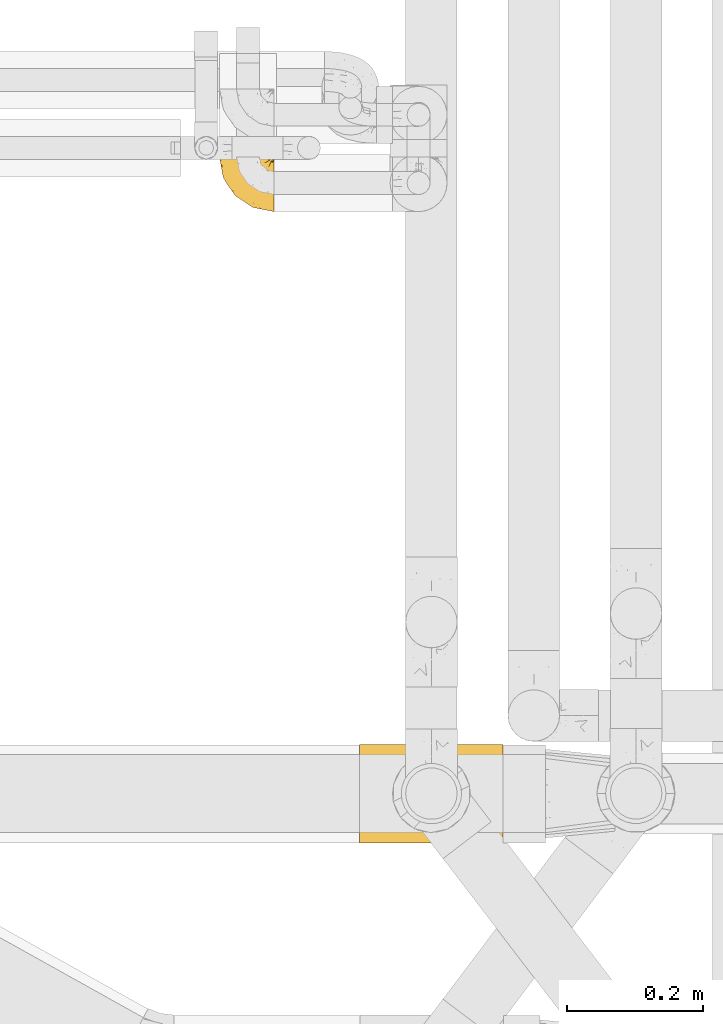
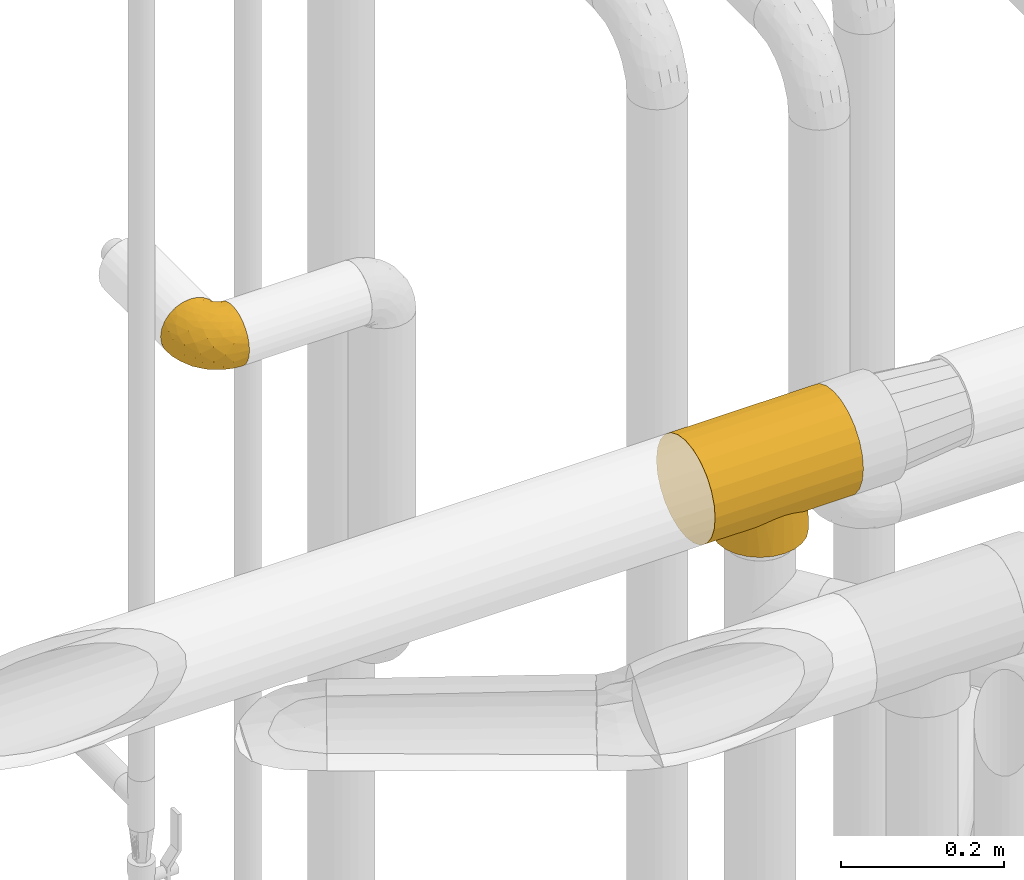
# One storey, part 353 of 827: 2 coverings.
"""IFC2X3 building model written with IfcOpenShell, lengths in millimetres."""

from ifc_helpers import new_model, entity, si_unit, converted_unit, derived_unit, direction, frame, origin, place, context, subcontext, project, spatial, faceted_brep, element, save


model = new_model("IFC2X3")

# Units and contexts
model_context = context("Model", 3, precision=0.01, world=origin(), true_north=direction((6.12303176911189e-17, 1.0)))
body_context = subcontext(model_context, "Body", "Model", "MODEL_VIEW")
ifc_project = project(units=[si_unit("LENGTHUNIT", "METRE", prefix="MILLI"), si_unit("AREAUNIT", "SQUARE_METRE"), si_unit("VOLUMEUNIT", "CUBIC_METRE"), converted_unit("PLANEANGLEUNIT", "DEGREE", entity("IfcRatioMeasure", 0.0174532925199433), si_unit("PLANEANGLEUNIT", "RADIAN"), dimensions=[0, 0, 0, 0, 0, 0, 0]), si_unit("MASSUNIT", "GRAM", prefix="KILO"), derived_unit("MASSDENSITYUNIT", [(si_unit("MASSUNIT", "GRAM", prefix="KILO"), 1), (si_unit("LENGTHUNIT", "METRE"), -3)]), derived_unit("MOMENTOFINERTIAUNIT", [(si_unit("LENGTHUNIT", "METRE"), 4)]), si_unit("TIMEUNIT", "SECOND"), si_unit("FREQUENCYUNIT", "HERTZ"), si_unit("THERMODYNAMICTEMPERATUREUNIT", "DEGREE_CELSIUS"), derived_unit("THERMALTRANSMITTANCEUNIT", [(si_unit("MASSUNIT", "GRAM", prefix="KILO"), 1), (si_unit("THERMODYNAMICTEMPERATUREUNIT", "KELVIN"), -1), (si_unit("TIMEUNIT", "SECOND"), -3)]), derived_unit("VOLUMETRICFLOWRATEUNIT", [(si_unit("LENGTHUNIT", "METRE"), 3), (si_unit("TIMEUNIT", "SECOND"), -1)]), derived_unit("MASSFLOWRATEUNIT", [(si_unit("MASSUNIT", "GRAM", prefix="KILO"), 1), (si_unit("TIMEUNIT", "SECOND"), -1)]), derived_unit("ROTATIONALFREQUENCYUNIT", [(si_unit("TIMEUNIT", "SECOND"), -1)]), si_unit("ELECTRICCURRENTUNIT", "AMPERE"), si_unit("ELECTRICVOLTAGEUNIT", "VOLT"), si_unit("POWERUNIT", "WATT"), si_unit("FORCEUNIT", "NEWTON", prefix="KILO"), si_unit("ILLUMINANCEUNIT", "LUX"), si_unit("LUMINOUSFLUXUNIT", "LUMEN"), si_unit("LUMINOUSINTENSITYUNIT", "CANDELA"), derived_unit("USERDEFINED", [(si_unit("MASSUNIT", "GRAM", prefix="KILO"), -1), (si_unit("LENGTHUNIT", "METRE"), -2), (si_unit("TIMEUNIT", "SECOND"), 3), (si_unit("LUMINOUSFLUXUNIT", "LUMEN"), 1)]), derived_unit("LINEARVELOCITYUNIT", [(si_unit("LENGTHUNIT", "METRE"), 1), (si_unit("TIMEUNIT", "SECOND"), -1)]), si_unit("PRESSUREUNIT", "PASCAL"), derived_unit("USERDEFINED", [(si_unit("LENGTHUNIT", "METRE"), -2), (si_unit("MASSUNIT", "GRAM", prefix="KILO"), 1), (si_unit("TIMEUNIT", "SECOND"), -2)]), derived_unit("LINEARFORCEUNIT", [(si_unit("MASSUNIT", "GRAM", prefix="KILO"), 1), (si_unit("LENGTHUNIT", "METRE"), 1), (si_unit("TIMEUNIT", "SECOND"), -2), (si_unit("LENGTHUNIT", "METRE"), -1)]), derived_unit("PLANARFORCEUNIT", [(si_unit("MASSUNIT", "GRAM", prefix="KILO"), 1), (si_unit("LENGTHUNIT", "METRE"), 1), (si_unit("TIMEUNIT", "SECOND"), -2), (si_unit("LENGTHUNIT", "METRE"), -2)])], contexts=[model_context])

# Site, building, storey
site_placement = place(None, origin())
site = spatial("IfcSite", under=ifc_project, at=site_placement, CompositionType="ELEMENT")
building_placement = place(site_placement, origin())
building = spatial("IfcBuilding", under=site, at=building_placement, CompositionType="ELEMENT")
storey_placement = place(building_placement, frame((0.0, 0.0, 28200.0)))
storey = spatial("IfcBuildingStorey", under=building, at=storey_placement, Name="08", CompositionType="ELEMENT", Elevation=28200.0)

# Coverings
covering_1_placement = place(storey_placement, frame((43282.77, 15137.81, 2190.84)))
element("IfcCovering", 1, at=covering_1_placement, inside=storey, Name=":ADSK_", ObjectType=":ADSK_", PredefinedType="INSULATION", context=body_context, shape_type="Brep", body=[
    faceted_brep([(81.45, 25.28, 81.15), (81.45, 17.35, 76.16), (81.45, 10.72, 69.53), (81.45, 5.74, 61.6), (81.45, 2.64, 52.75), (81.45, 1.6, 43.45), (81.45, 2.65, 34.13), (81.45, 5.74, 25.28), (81.45, 10.73, 17.35), (81.45, 17.36, 10.72), (81.45, 25.29, 5.74), (81.45, 34.14, 2.64), (81.45, 43.45, 1.6), (81.45, 52.82, 2.66), (81.45, 61.71, 5.79), (81.45, 69.67, 10.83), (81.45, 76.31, 17.53), (81.45, 81.27, 25.53), (81.45, 81.27, 26.45), (81.45, 81.27, 27.37), (81.45, 81.27, 28.17), (81.45, 81.27, 29.49), (81.45, 81.27, 30.81), (81.45, 81.27, 32.13), (81.45, 81.27, 33.45), (81.45, 81.27, 34.78), (81.45, 81.27, 36.1), (81.45, 81.27, 37.42), (81.45, 81.27, 38.74), (81.45, 81.27, 40.06), (81.45, 81.27, 41.38), (81.45, 81.27, 42.7), (81.45, 81.27, 44.02), (81.45, 81.27, 45.34), (81.45, 81.27, 46.66), (81.45, 81.27, 47.58), (81.45, 81.27, 48.5), (81.45, 81.27, 49.41), (81.45, 81.27, 50.33), (81.45, 81.27, 51.25), (81.45, 81.27, 52.17), (81.45, 81.27, 53.09), (81.45, 81.27, 54.01), (81.45, 81.27, 54.93), (81.45, 81.27, 55.85), (81.45, 81.27, 56.76), (81.45, 81.27, 57.68), (81.45, 81.27, 58.6), (81.45, 81.27, 59.52), (81.45, 81.27, 60.44), (81.45, 81.27, 61.36), (81.45, 76.3, 69.37), (81.45, 69.66, 76.07), (81.45, 61.69, 81.11), (81.45, 52.8, 84.24), (81.45, 43.45, 85.3), (81.45, 34.13, 84.24), (76.3, 81.45, 17.52), (69.67, 81.45, 10.83), (61.7, 81.45, 5.79), (52.81, 81.45, 2.66), (43.45, 81.45, 1.6), (32.61, 81.45, 3.02), (22.52, 81.45, 7.2), (13.85, 81.45, 13.85), (7.2, 81.45, 22.52), (3.02, 81.45, 32.61), (1.6, 81.45, 43.45), (3.02, 81.45, 54.28), (7.2, 81.45, 64.37), (13.85, 81.45, 73.04), (22.52, 81.45, 79.69), (32.61, 81.45, 83.87), (43.45, 81.45, 85.3), (52.81, 81.45, 84.23), (61.7, 81.45, 81.1), (69.67, 81.45, 76.06), (76.3, 81.45, 69.37), (81.27, 81.45, 61.36), (81.27, 81.45, 60.44), (81.27, 81.45, 59.12), (81.27, 81.45, 58.0), (81.27, 81.45, 56.88), (81.27, 81.45, 55.76), (81.27, 81.45, 54.64), (81.27, 81.45, 53.52), (81.27, 81.45, 52.4), (81.27, 81.45, 51.28), (81.27, 81.45, 50.16), (81.27, 81.45, 49.04), (81.27, 81.45, 47.92), (81.27, 81.45, 46.8), (81.27, 81.45, 45.68), (81.27, 81.45, 44.56), (81.27, 81.45, 43.45), (81.27, 81.45, 42.12), (81.27, 81.45, 40.8), (81.27, 81.45, 39.48), (81.27, 81.45, 38.16), (81.27, 81.45, 36.84), (81.27, 81.45, 35.52), (81.27, 81.45, 34.2), (81.27, 81.45, 32.88), (81.27, 81.45, 31.96), (81.27, 81.45, 31.05), (81.27, 81.45, 30.13), (81.27, 81.45, 29.21), (81.27, 81.45, 28.29), (81.27, 81.45, 27.37), (81.27, 81.45, 26.45), (81.27, 81.45, 25.53), (81.31, 81.33, 54.08), (81.33, 81.32, 55.16), (81.31, 81.33, 36.18), (81.32, 81.32, 35.13), (81.31, 81.33, 44.01), (81.32, 81.32, 45.08), (81.32, 81.32, 61.36), (81.32, 81.32, 59.98), (81.32, 81.32, 46.18), (81.32, 81.32, 26.74), (81.32, 81.32, 47.36), (81.32, 81.32, 29.67), (81.3, 81.34, 28.72), (81.32, 81.32, 39.77), (81.33, 81.31, 52.96), (81.31, 81.33, 51.84), (81.33, 81.31, 40.8), (81.32, 81.32, 41.87), (81.32, 81.33, 42.94), (81.32, 81.32, 27.77), (81.31, 81.33, 48.4), (81.32, 81.32, 37.21), (81.31, 81.33, 33.54), (81.32, 81.32, 32.49), (81.32, 81.32, 30.69), (81.32, 81.32, 50.69), (81.33, 81.31, 49.6), (81.32, 81.32, 56.32), (81.31, 81.33, 57.44), (81.33, 81.31, 58.88), (81.32, 81.32, 25.53), (81.36, 81.3, 61.36), (81.4, 81.29, 61.36), (81.4, 81.29, 25.53), (81.36, 81.3, 25.53), (81.29, 81.4, 61.36), (81.3, 81.36, 61.36), (81.3, 81.36, 25.53), (81.29, 81.4, 25.53), (81.35, 81.3, 31.59), (81.31, 81.33, 38.71), (58.5, 74.06, 3.97), (71.95, 45.99, 1.6), (74.57, 58.35, 3.97), (73.93, 67.76, 8.09), (78.18, 66.18, 8.09), (78.04, 76.46, 16.43), (76.23, 77.33, 15.73), (45.99, 71.95, 1.6), (74.01, 72.25, 10.79), (73.57, 78.91, 13.99), (66.66, 76.42, 8.08), (79.09, 73.52, 14.0), (73.14, 76.9, 12.83), (60.34, 65.25, 3.18), (48.54, 62.45, 1.6), (45.36, 74.31, 1.6), (67.22, 59.38, 3.28), (62.45, 48.54, 1.6), (68.67, 67.72, 6.28), (55.49, 55.49, 1.6), (77.84, 79.73, 19.06), (68.16, 73.23, 8.08), (74.31, 45.36, 1.6), (38.78, 15.81, 32.11), (62.1, 6.4, 29.62), (50.89, 7.67, 43.45), (36.91, 68.46, 2.45), (40.37, 59.33, 2.5), (27.86, 48.7, 9.73), (15.77, 53.94, 17.97), (20.13, 65.02, 10.24), (31.54, 60.77, 4.78), (28.25, 72.07, 4.78), (57.26, 26.25, 8.01), (69.99, 22.29, 8.01), (64.58, 16.0, 13.85), (50.64, 46.93, 2.42), (51.97, 14.19, 21.17), (5.72, 58.46, 35.73), (7.42, 61.51, 27.43), (66.14, 4.64, 43.45), (11.35, 68.93, 17.97), (21.64, 29.62, 35.71), (28.57, 24.85, 29.47), (55.38, 38.55, 3.41), (68.51, 31.27, 3.94), (67.48, 9.35, 21.17), (40.78, 37.15, 7.92), (41.53, 47.07, 4.25), (46.11, 26.49, 11.75), (40.32, 23.01, 18.31), (38.36, 19.4, 24.94), (11.84, 48.06, 28.78), (12.56, 42.46, 35.82), (7.67, 50.89, 43.45), (19.39, 35.78, 28.38), (24.98, 24.98, 43.45), (37.94, 16.33, 43.45), (4.64, 66.14, 43.45), (28.09, 30.96, 21.21), (23.73, 41.83, 16.48), (34.03, 33.28, 13.85), (16.33, 37.94, 43.45), (29.29, 67.39, 82.11), (5.77, 58.47, 51.41), (21.44, 32.5, 57.45), (38.8, 15.79, 54.78), (64.58, 15.99, 73.03), (67.49, 9.34, 65.7), (22.9, 56.91, 76.65), (12.54, 63.5, 68.92), (20.04, 44.08, 68.01), (57.26, 26.24, 78.88), (69.99, 22.27, 78.88), (68.51, 31.26, 82.94), (34.54, 23.95, 64.44), (38.81, 63.79, 84.49), (48.54, 62.45, 85.3), (45.99, 71.95, 85.3), (74.31, 45.36, 85.3), (5.36, 67.83, 57.84), (18.96, 70.28, 76.65), (12.79, 42.11, 51.19), (62.11, 6.39, 57.26), (33.14, 43.54, 78.14), (33.44, 58.03, 82.35), (51.98, 14.18, 65.7), (43.42, 56.34, 84.61), (48.62, 48.09, 84.36), (62.45, 48.54, 85.3), (55.49, 55.49, 85.3), (49.68, 21.78, 73.03), (55.37, 38.54, 83.48), (71.95, 45.99, 85.3), (36.37, 72.79, 84.54), (34.04, 33.26, 73.03), (44.1, 35.53, 79.54), (9.99, 53.66, 59.46), (26.41, 43.03, 73.5), (39.19, 49.68, 82.57), (58.5, 74.06, 82.92), (67.22, 59.37, 83.62), (74.57, 58.34, 82.92), (73.92, 67.75, 78.81), (73.57, 78.91, 72.9), (73.14, 76.9, 74.06), (66.19, 78.08, 78.81), (68.16, 73.23, 78.81), (77.84, 79.73, 67.83), (76.23, 77.34, 71.15), (79.08, 73.51, 72.91), (78.04, 76.45, 70.47), (77.18, 66.41, 78.81), (68.66, 67.7, 80.62), (74.0, 72.24, 76.11), (60.34, 65.25, 83.71)], [[[0, 1, 2, 3, 4, 5, 6, 7, 8, 9, 10, 11, 12, 13, 14, 15, 16, 17, 18, 19, 20, 21, 22, 23, 24, 25, 26, 27, 28, 29, 30, 31, 32, 33, 34, 35, 36, 37, 38, 39, 40, 41, 42, 43, 44, 45, 46, 47, 48, 49, 50, 51, 52, 53, 54, 55, 56]], [[57, 58, 59, 60, 61, 62, 63, 64, 65, 66, 67, 68, 69, 70, 71, 72, 73, 74, 75, 76, 77, 78, 79, 80, 81, 82, 83, 84, 85, 86, 87, 88, 89, 90, 91, 92, 93, 94, 95, 96, 97, 98, 99, 100, 101, 102, 103, 104, 105, 106, 107, 108, 109, 110]], [[111, 84, 112]], [[113, 26, 114]], [[114, 101, 100]], [[115, 93, 116]], [[79, 117, 118]], [[33, 116, 119]], [[117, 49, 118]], [[19, 18, 120]], [[119, 121, 34]], [[122, 21, 123]], [[97, 96, 124]], [[86, 125, 126]], [[116, 92, 119]], [[127, 96, 128]], [[32, 129, 115]], [[19, 120, 130]], [[121, 90, 131]], [[94, 115, 129]], [[115, 116, 32]], [[118, 49, 48]], [[113, 99, 132]], [[133, 114, 25]], [[24, 134, 133]], [[135, 22, 122]], [[136, 137, 88]], [[84, 83, 112]], [[138, 82, 139]], [[130, 20, 19]], [[118, 48, 140]], [[81, 140, 139]], [[123, 21, 20]], [[141, 120, 18]], [[139, 82, 81]], [[130, 107, 123]], [[49, 117, 142, 143, 50]], [[18, 17, 144, 145, 141]], [[79, 78, 146, 147, 117]], [[109, 141, 148, 149, 110]], [[102, 133, 134]], [[105, 135, 122]], [[118, 80, 79]], [[80, 118, 140]], [[120, 109, 108]], [[47, 46, 140, 48]], [[81, 80, 140]], [[44, 112, 138]], [[93, 115, 94]], [[46, 139, 140]], [[46, 45, 139]], [[139, 45, 138]], [[138, 112, 83]], [[85, 84, 111]], [[112, 43, 111]], [[83, 82, 138]], [[106, 122, 123]], [[105, 122, 106]], [[21, 122, 22]], [[124, 29, 28]], [[33, 32, 116]], [[128, 129, 31]], [[32, 31, 129]], [[34, 33, 119]], [[116, 93, 92]], [[129, 95, 94]], [[95, 129, 128]], [[41, 40, 125, 42]], [[119, 91, 121]], [[36, 35, 131, 37]], [[137, 131, 89]], [[121, 131, 35]], [[90, 121, 91]], [[119, 92, 91]], [[136, 126, 39]], [[125, 86, 85]], [[42, 125, 111]], [[85, 111, 125]], [[150, 23, 22]], [[130, 108, 107]], [[130, 123, 20]], [[107, 106, 123]], [[137, 37, 131]], [[136, 38, 137]], [[89, 88, 137]], [[131, 90, 89]], [[124, 151, 97]], [[40, 39, 126]], [[87, 126, 136]], [[86, 126, 87]], [[136, 88, 87]], [[40, 126, 125]], [[39, 38, 136]], [[95, 128, 96]], [[30, 128, 31]], [[29, 124, 127]], [[127, 128, 30]], [[151, 124, 28]], [[127, 30, 29]], [[127, 124, 96]], [[151, 98, 97]], [[45, 44, 138]], [[26, 113, 132]], [[113, 100, 99]], [[132, 151, 27]], [[27, 26, 132]], [[26, 25, 114]], [[100, 113, 114]], [[101, 133, 102]], [[133, 101, 114]], [[28, 27, 151]], [[132, 99, 98]], [[23, 134, 24]], [[25, 24, 133]], [[134, 23, 150]], [[135, 104, 150]], [[150, 104, 103]], [[103, 102, 134]], [[130, 120, 108]], [[109, 120, 141]], [[42, 111, 43]], [[112, 44, 43]], [[104, 135, 105]], [[134, 150, 103]], [[135, 150, 22]], [[35, 34, 121]], [[137, 38, 37]], [[98, 151, 132]], [[59, 152, 60]], [[13, 153, 154]], [[155, 156, 154]], [[157, 158, 141]], [[159, 60, 152]], [[160, 157, 155]], [[161, 162, 58]], [[58, 162, 59]], [[144, 16, 163]], [[58, 57, 161]], [[162, 161, 164]], [[157, 163, 155]], [[163, 16, 15]], [[57, 149, 161]], [[152, 165, 166]], [[157, 144, 163]], [[60, 159, 167, 61]], [[156, 14, 154]], [[163, 156, 155]], [[155, 154, 168]], [[168, 154, 169]], [[155, 170, 160]], [[57, 110, 149]], [[144, 17, 16]], [[156, 15, 14]], [[171, 165, 168]], [[158, 164, 172]], [[14, 13, 154]], [[157, 141, 145, 144]], [[173, 164, 158]], [[173, 160, 170]], [[171, 166, 165]], [[168, 165, 170]], [[168, 169, 171]], [[152, 173, 165]], [[170, 155, 168]], [[165, 173, 170]], [[160, 173, 158]], [[172, 149, 148]], [[148, 141, 158]], [[158, 157, 160]], [[152, 166, 159]], [[173, 152, 162]], [[59, 162, 152]], [[13, 12, 174, 153]], [[153, 169, 154]], [[15, 156, 163]], [[162, 164, 173]], [[172, 164, 161]], [[149, 172, 161]], [[158, 172, 148]], [[175, 176, 177]], [[178, 166, 179]], [[180, 181, 182]], [[183, 184, 178]], [[185, 186, 187]], [[171, 188, 179]], [[174, 12, 11]], [[189, 176, 175]], [[190, 66, 191]], [[176, 6, 192]], [[193, 65, 64]], [[63, 184, 182]], [[63, 182, 64]], [[65, 193, 191]], [[184, 63, 62]], [[175, 194, 195]], [[196, 169, 197]], [[174, 11, 197]], [[8, 7, 198]], [[187, 9, 8]], [[197, 169, 153, 174]], [[197, 11, 10]], [[186, 197, 10]], [[199, 180, 200]], [[197, 185, 196]], [[201, 189, 202]], [[201, 187, 189]], [[195, 203, 175]], [[191, 204, 190]], [[176, 7, 6]], [[177, 176, 192]], [[189, 198, 176]], [[65, 191, 66]], [[198, 187, 8]], [[205, 206, 190]], [[9, 186, 10]], [[181, 207, 204]], [[208, 175, 177, 209]], [[66, 190, 210]], [[211, 212, 213]], [[190, 204, 205]], [[180, 182, 183]], [[193, 182, 181]], [[62, 61, 167]], [[196, 185, 199]], [[196, 200, 188]], [[6, 5, 192]], [[176, 198, 7]], [[187, 198, 189]], [[187, 186, 9]], [[197, 186, 185]], [[200, 180, 183]], [[180, 213, 212]], [[179, 183, 178]], [[185, 201, 199]], [[210, 190, 206]], [[210, 67, 66]], [[205, 204, 207]], [[194, 205, 207]], [[194, 214, 205]], [[195, 194, 207]], [[208, 194, 175]], [[207, 211, 195]], [[202, 203, 211]], [[212, 207, 181]], [[202, 211, 213]], [[201, 202, 213]], [[189, 175, 203]], [[199, 201, 213]], [[187, 201, 185]], [[180, 199, 213]], [[196, 199, 200]], [[211, 203, 195]], [[189, 203, 202]], [[207, 212, 211]], [[180, 212, 181]], [[214, 194, 208]], [[214, 206, 205]], [[196, 188, 169]], [[181, 204, 191]], [[182, 193, 64]], [[191, 193, 181]], [[178, 62, 167]], [[182, 184, 183]], [[62, 178, 184]], [[178, 167, 159, 166]], [[171, 179, 166]], [[200, 183, 179]], [[179, 188, 200]], [[169, 188, 171]], [[71, 215, 72]], [[206, 216, 210]], [[217, 208, 218]], [[216, 68, 210]], [[219, 220, 2]], [[221, 222, 223]], [[224, 225, 226]], [[227, 223, 217]], [[228, 229, 230]], [[56, 231, 226]], [[232, 222, 69]], [[56, 55, 231]], [[70, 233, 71]], [[71, 233, 215]], [[0, 56, 226]], [[208, 217, 234]], [[218, 177, 235]], [[221, 236, 237]], [[238, 220, 219]], [[1, 219, 2]], [[68, 216, 232]], [[235, 3, 220]], [[235, 192, 4]], [[1, 0, 225]], [[228, 239, 229]], [[240, 241, 242]], [[243, 238, 219]], [[224, 226, 244]], [[226, 241, 244]], [[3, 235, 4]], [[69, 222, 70]], [[225, 219, 1]], [[218, 235, 238]], [[243, 219, 224]], [[218, 227, 217]], [[3, 2, 220]], [[218, 208, 209, 177]], [[226, 231, 245, 241]], [[215, 228, 246]], [[247, 248, 236]], [[248, 224, 244]], [[223, 222, 249]], [[233, 222, 221]], [[242, 239, 240]], [[248, 247, 243]], [[217, 223, 249]], [[250, 247, 236]], [[216, 234, 249]], [[218, 238, 227]], [[192, 235, 177]], [[192, 5, 4]], [[72, 246, 73]], [[235, 220, 238]], [[226, 225, 0]], [[219, 225, 224]], [[240, 248, 244]], [[239, 242, 229]], [[236, 248, 251]], [[68, 67, 210]], [[234, 216, 206]], [[216, 249, 232]], [[234, 206, 214, 208]], [[249, 234, 217]], [[222, 232, 249]], [[69, 68, 232]], [[246, 228, 230]], [[237, 228, 215]], [[243, 227, 238]], [[223, 227, 247]], [[73, 246, 230]], [[215, 246, 72]], [[248, 243, 224]], [[227, 243, 247]], [[237, 236, 251]], [[250, 221, 223]], [[222, 233, 70]], [[215, 233, 221]], [[221, 237, 215]], [[239, 237, 251]], [[237, 239, 228]], [[239, 251, 240]], [[248, 240, 251]], [[241, 240, 244]], [[221, 250, 236]], [[223, 247, 250]], [[74, 230, 252]], [[253, 254, 255]], [[146, 77, 256]], [[257, 258, 259]], [[260, 256, 257]], [[260, 261, 147]], [[75, 74, 252]], [[51, 143, 262]], [[263, 143, 142, 117]], [[256, 77, 76]], [[252, 258, 75]], [[253, 241, 254]], [[254, 245, 54]], [[258, 256, 76]], [[53, 52, 264]], [[255, 265, 253]], [[254, 264, 255]], [[255, 264, 262]], [[75, 258, 76]], [[265, 255, 266]], [[255, 262, 263]], [[51, 50, 143]], [[54, 245, 231, 55]], [[51, 262, 52]], [[253, 267, 242]], [[254, 54, 53]], [[266, 259, 265]], [[146, 78, 77]], [[263, 117, 261]], [[146, 256, 260]], [[257, 259, 261]], [[267, 253, 265]], [[229, 267, 252]], [[242, 267, 229]], [[242, 241, 253]], [[252, 267, 259]], [[255, 263, 266]], [[259, 267, 265]], [[261, 117, 147]], [[263, 261, 266]], [[259, 266, 261]], [[230, 74, 73]], [[230, 229, 252]], [[259, 258, 252]], [[254, 241, 245]], [[53, 264, 254]], [[52, 262, 264]], [[143, 263, 262]], [[258, 257, 256]], [[261, 260, 257]], [[146, 260, 147]]]),
])
covering_2_placement = place(storey_placement, frame((43490.03, 14212.87, 2402.0)))
element("IfcCovering", 2, at=covering_2_placement, inside=storey, Name=":ADSK_", ObjectType=":ADSK_", PredefinedType="INSULATION", context=body_context, shape_type="Brep", body=[
    faceted_brep([(210.0, 143.44, 116.67), (210.0, 136.23, 134.08), (210.0, 124.76, 149.02), (210.0, 109.82, 160.48), (210.0, 92.42, 167.69), (210.0, 73.75, 170.15), (210.0, 55.07, 167.69), (210.0, 37.67, 160.48), (210.0, 22.73, 149.02), (210.0, 11.26, 134.08), (210.0, 4.05, 116.67), (210.0, 1.6, 98.0), (210.0, 4.05, 79.33), (210.0, 11.26, 61.93), (210.0, 22.73, 46.98), (210.0, 30.2, 41.25), (210.0, 37.67, 35.52), (210.0, 46.37, 31.91), (210.0, 55.07, 28.31), (210.0, 64.41, 27.08), (210.0, 73.75, 25.85), (210.0, 83.08, 27.08), (210.0, 92.42, 28.31), (210.0, 101.12, 31.91), (210.0, 109.82, 35.52), (210.0, 117.29, 41.25), (210.0, 124.76, 46.98), (210.0, 136.23, 61.93), (210.0, 143.44, 79.33), (210.0, 145.9, 98.0), (0.0, 1.6, 98.0), (0.0, 4.05, 116.67), (0.0, 11.26, 134.08), (0.0, 22.73, 149.02), (0.0, 37.67, 160.48), (0.0, 55.07, 167.69), (0.0, 73.75, 170.15), (0.0, 92.42, 167.69), (0.0, 109.82, 160.48), (0.0, 124.76, 149.02), (0.0, 136.23, 134.08), (0.0, 143.44, 116.67), (0.0, 145.9, 98.0), (0.0, 143.44, 79.33), (0.0, 136.23, 61.93), (0.0, 124.76, 46.98), (0.0, 117.29, 41.25), (0.0, 109.82, 35.52), (0.0, 101.12, 31.91), (0.0, 92.42, 28.31), (0.0, 83.08, 27.08), (0.0, 73.75, 25.85), (0.0, 64.41, 27.08), (0.0, 55.07, 28.31), (0.0, 46.37, 31.91), (0.0, 37.67, 35.52), (0.0, 30.2, 41.25), (0.0, 22.73, 46.98), (0.0, 11.26, 61.93), (0.0, 4.05, 79.33), (105.0, 14.3, 57.12), (71.94, 24.33, 45.43), (81.73, 19.04, 50.96), (159.49, 49.97, 29.88), (92.81, 15.56, 55.34), (63.4, 31.27, 39.67), (117.19, 15.56, 55.34), (128.27, 19.04, 50.96), (164.45, 73.75, 25.85), (163.16, 61.45, 26.91), (138.06, 24.33, 45.43), (146.6, 31.27, 39.67), (56.17, 39.84, 34.31), (50.51, 49.97, 29.88), (46.84, 61.45, 26.91), (161.33, 55.71, 28.39), (45.55, 73.75, 25.85), (48.67, 55.71, 28.39), (153.83, 39.84, 34.31), (46.84, 86.04, 26.91), (56.17, 107.65, 34.31), (50.51, 97.52, 29.88), (63.4, 116.22, 39.67), (48.67, 91.78, 28.39), (163.16, 86.04, 26.91), (161.33, 91.78, 28.39), (159.49, 97.52, 29.88), (153.83, 107.65, 34.31), (146.6, 116.22, 39.67), (71.94, 123.16, 45.43), (81.73, 128.45, 50.96), (92.81, 131.93, 55.34), (105.0, 133.2, 57.12), (138.06, 123.16, 45.43), (128.27, 128.45, 50.96), (117.19, 131.93, 55.34), (105.0, 14.3, 0.0), (89.61, 16.32, 0.0), (75.27, 22.26, 0.0), (62.96, 31.71, 0.0), (53.51, 44.02, 0.0), (47.58, 58.36, 0.0), (45.55, 73.75, 0.0), (47.58, 89.13, 0.0), (53.51, 103.47, 0.0), (62.96, 115.78, 0.0), (75.27, 125.23, 0.0), (89.61, 131.17, 0.0), (105.0, 133.2, 0.0), (120.39, 131.17, 0.0), (134.72, 125.23, 0.0), (147.04, 115.78, 0.0), (156.49, 103.47, 0.0), (162.42, 89.13, 0.0), (164.45, 73.75, 0.0), (162.42, 58.36, 0.0), (156.49, 44.02, 0.0), (147.04, 31.71, 0.0), (134.72, 22.26, 0.0), (120.39, 16.32, 0.0)], [[[0, 1, 2, 3, 4, 5, 6, 7, 8, 9, 10, 11, 12, 13, 14, 15, 16, 17, 18, 19, 20, 21, 22, 23, 24, 25, 26, 27, 28, 29]], [[30, 31, 32, 33, 34, 35, 36, 37, 38, 39, 40, 41, 42, 43, 44, 45, 46, 47, 48, 49, 50, 51, 52, 53, 54, 55, 56, 57, 58, 59]], [[34, 33, 8, 7]], [[5, 36, 35, 6]], [[6, 35, 34, 7]], [[9, 32, 31, 10]], [[10, 31, 30, 11]], [[8, 33, 32, 9]], [[59, 12, 11, 30]], [[58, 60, 59]], [[57, 61, 62]], [[57, 56, 61]], [[63, 18, 17]], [[64, 58, 62]], [[61, 56, 65]], [[62, 58, 57]], [[64, 60, 58]], [[12, 59, 60]], [[13, 12, 60]], [[60, 66, 13]], [[67, 14, 13]], [[68, 19, 69]], [[70, 71, 15]], [[70, 14, 67]], [[71, 16, 15]], [[67, 13, 66]], [[72, 54, 73]], [[74, 53, 52]], [[54, 72, 55]], [[73, 54, 53]], [[18, 63, 75, 69]], [[72, 65, 55]], [[55, 65, 56]], [[51, 76, 52]], [[68, 20, 19]], [[74, 52, 76]], [[53, 74, 77, 73]], [[71, 78, 16]], [[78, 17, 16]], [[17, 78, 63]], [[15, 14, 70]], [[19, 18, 69]], [[51, 50, 76]], [[20, 68, 21]], [[79, 50, 49]], [[47, 80, 48]], [[81, 48, 80]], [[47, 82, 80]], [[49, 81, 83, 79]], [[84, 21, 68]], [[85, 86, 22, 84]], [[24, 87, 88]], [[86, 23, 22]], [[23, 87, 24]], [[82, 47, 46]], [[45, 89, 46]], [[89, 45, 90]], [[81, 49, 48]], [[44, 91, 90]], [[90, 45, 44]], [[84, 22, 21]], [[92, 43, 28]], [[92, 44, 43]], [[44, 92, 91]], [[43, 42, 29, 28]], [[93, 25, 88]], [[93, 94, 26]], [[88, 25, 24]], [[25, 93, 26]], [[94, 27, 26]], [[76, 50, 79]], [[95, 27, 94]], [[95, 92, 27]], [[27, 92, 28]], [[87, 23, 86]], [[82, 46, 89]], [[0, 41, 40, 1]], [[1, 40, 39, 2]], [[42, 41, 0, 29]], [[3, 38, 37, 4]], [[4, 37, 36, 5]], [[2, 39, 38, 3]], [[96, 97, 98, 99, 100, 101, 102, 103, 104, 105, 106, 107, 108, 109, 110, 111, 112, 113, 114, 115, 116, 117, 118, 119]], [[74, 102, 101]], [[100, 99, 72]], [[73, 101, 100]], [[74, 76, 102]], [[72, 73, 100]], [[101, 73, 77, 74]], [[99, 65, 72]], [[65, 99, 61]], [[61, 99, 98]], [[62, 98, 97]], [[64, 97, 96]], [[61, 98, 62]], [[64, 62, 97]], [[60, 64, 96]], [[66, 96, 119]], [[119, 118, 67]], [[117, 70, 118]], [[117, 71, 70]], [[60, 96, 66]], [[66, 119, 67]], [[118, 70, 67]], [[78, 117, 116]], [[63, 116, 115]], [[69, 115, 114]], [[63, 78, 116]], [[68, 69, 114]], [[115, 69, 75, 63]], [[117, 78, 71]], [[84, 114, 113]], [[113, 112, 86]], [[111, 87, 112]], [[84, 68, 114]], [[87, 86, 112]], [[113, 86, 85, 84]], [[111, 88, 87]], [[88, 111, 93]], [[93, 111, 110]], [[94, 110, 109]], [[95, 109, 108]], [[93, 110, 94]], [[95, 94, 109]], [[92, 95, 108]], [[91, 108, 107]], [[107, 106, 90]], [[105, 89, 106]], [[105, 82, 89]], [[92, 108, 91]], [[91, 107, 90]], [[106, 89, 90]], [[80, 105, 104]], [[81, 104, 103]], [[79, 103, 102]], [[81, 80, 104]], [[76, 79, 102]], [[103, 79, 83, 81]], [[105, 80, 82]]]),
])

save(model, "model.ifc")
